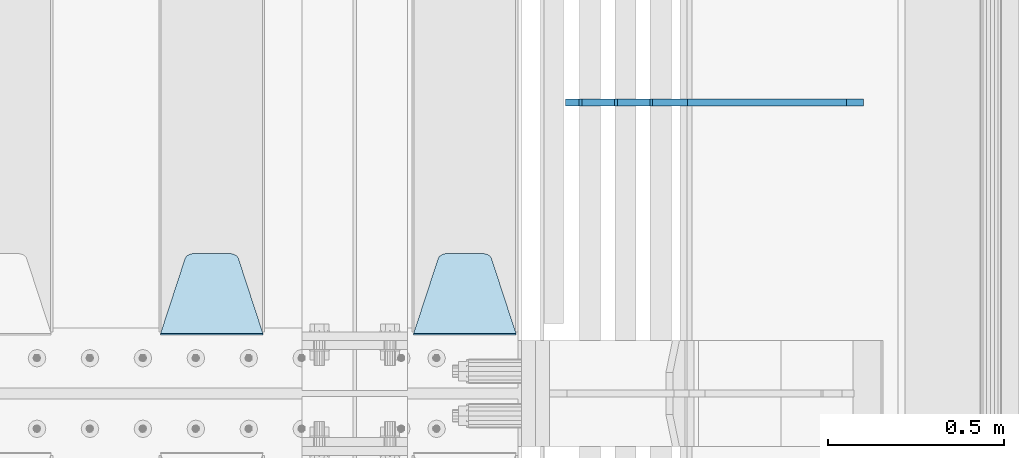
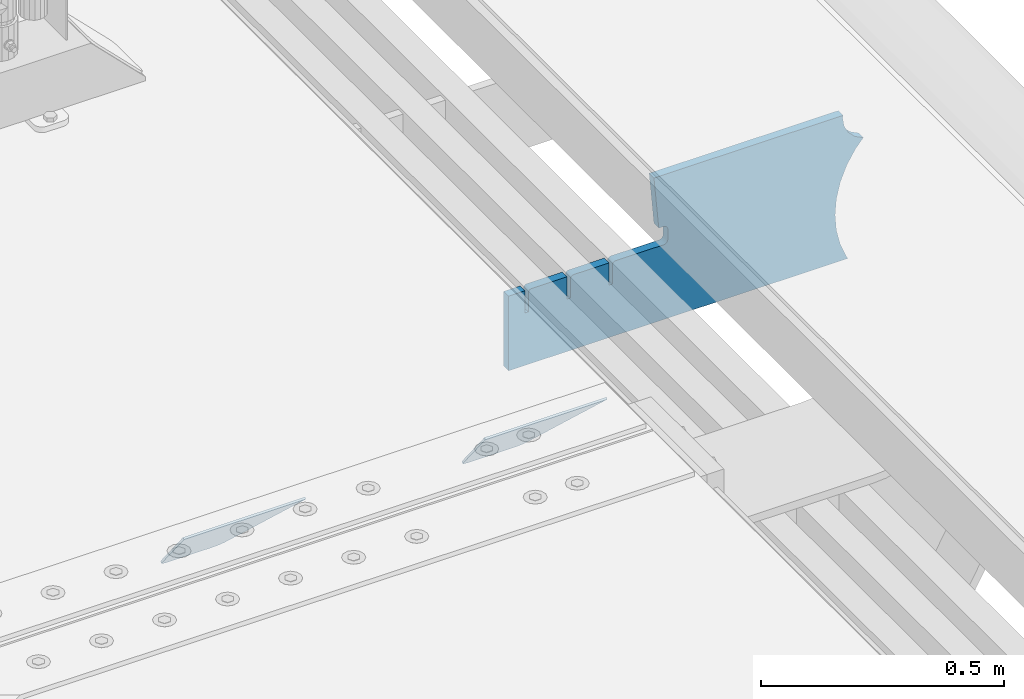
# One storey, part 192 of 219: 3 plates.
"""IFC2X3 building model written with IfcOpenShell, lengths in millimetres."""

from ifc_helpers import new_model, si_unit, frame, origin_with_axes, place, context, subcontext, project, spatial, faceted_brep, material, type_object, element, save


model = new_model("IFC2X3")

# Units and contexts
model_context = context("Model", 3, precision=1e-05, world=origin_with_axes())
body_context = subcontext(model_context, "Body", "Model", "MODEL_VIEW")
ifc_project = project(units=[si_unit("LENGTHUNIT", "METRE", prefix="MILLI"), si_unit("AREAUNIT", "SQUARE_METRE"), si_unit("VOLUMEUNIT", "CUBIC_METRE"), si_unit("MASSUNIT", "GRAM", prefix="KILO"), si_unit("TIMEUNIT", "SECOND"), si_unit("PLANEANGLEUNIT", "RADIAN"), si_unit("SOLIDANGLEUNIT", "STERADIAN"), si_unit("THERMODYNAMICTEMPERATUREUNIT", "DEGREE_CELSIUS"), si_unit("LUMINOUSINTENSITYUNIT", "LUMEN")], contexts=[model_context])

# Site, building, storey
site_placement = place(None, origin_with_axes())
site = spatial("IfcSite", under=ifc_project, at=site_placement, CompositionType="ELEMENT")
building_placement = place(site_placement, origin_with_axes())
building = spatial("IfcBuilding", under=site, at=building_placement, Name="Standard", CompositionType="ELEMENT")
storey_placement = place(building_placement, origin_with_axes())
storey = spatial("IfcBuildingStorey", under=building, at=storey_placement, Name="Undefined", CompositionType="ELEMENT", Elevation=0.0)

# Plates
ifc_material = material(Name="STEEL/S355N")
plate_type_1 = type_object("IfcPlateType", PredefinedType="NOTDEFINED")
plate_1_placement = place(storey_placement, frame((14012.0, 30168.232233047, -1.76776695296758), z_axis=(0.0, 0.707106781186547, -0.707106781186548), x_axis=(-1.0, 0.0, 0.0)))
element("IfcPlate", 1, at=plate_1_placement, inside=storey, type_object=plate_type_1, material=ifc_material, context=body_context, shape_type="Brep", body=[
    faceted_brep([(0.0, -2.5, 0.0), (69.345504679477, -2.5, 300.171731424834), (69.345504679477, 2.49999999999636, 300.171731424831), (0.0, 2.5, 0.0), (70.9274061199576, -2.50000000000364, 304.8974424154), (70.9274061199576, 2.49999999999636, 304.8974424154), (73.3818627772307, -2.50000000000364, 309.234538108532), (73.3818627772307, 2.49999999999636, 309.234538108532), (76.6187032999569, -2.50000000000364, 313.023683126106), (76.6187032999569, 2.49999999999636, 313.023683126106), (80.5190132704993, -2.50000000000364, 316.125672595372), (80.5190132704993, 2.49999999999636, 316.125672595372), (84.9395038596831, -2.50000000000364, 318.426546230476), (84.9395038596831, 2.5, 318.426546230479), (89.7177759439237, -2.50000000000364, 319.841774983277), (89.7177759439237, 2.5, 319.841774983281), (94.6782862926502, -2.50000000000364, 320.319366455078), (94.6782862926502, 2.49999999999636, 320.319366455078), (195.32171370735, -2.50000000000364, 320.319366455078), (195.32171370735, 2.49999999999636, 320.319366455078), (200.282224056076, -2.50000000000364, 319.841774983277), (200.282224056076, 2.5, 319.841774983281), (205.060496140317, -2.50000000000364, 318.426546230476), (205.060496140317, 2.49999999999636, 318.426546230476), (209.480986729501, -2.50000000000364, 316.125672595372), (209.480986729501, 2.49999999999636, 316.125672595372), (213.381296700043, -2.50000000000364, 313.023683126106), (213.381296700043, 2.49999999999272, 313.023683126106), (216.618137222769, -2.50000000000364, 309.234538108529), (216.618137222769, 2.49999999999636, 309.234538108525), (219.072593880042, -2.50000000000364, 304.8974424154), (219.072593880042, 2.49999999999636, 304.8974424154), (220.654495320523, -2.5, 300.171731424834), (220.654495320523, 2.49999999999636, 300.171731424831), (290.0, -2.50000000000364, 3.63797880709171e-12), (290.0, 2.49999999999636, 0.0)], [[[0, 1, 2, 3]], [[1, 4, 5, 2]], [[4, 6, 7, 5]], [[6, 8, 9, 7]], [[8, 10, 11, 9]], [[10, 12, 13, 11]], [[12, 14, 15, 13]], [[14, 16, 17, 15]], [[16, 18, 19, 17]], [[18, 20, 21, 19]], [[20, 22, 23, 21]], [[22, 24, 25, 23]], [[24, 26, 27, 25]], [[26, 28, 29, 27]], [[28, 30, 31, 29]], [[30, 32, 33, 31]], [[32, 34, 35, 33]], [[34, 0, 3, 35]], [[5, 7, 9, 11, 13, 15, 17, 19, 21, 23, 25, 27, 29, 31, 33, 35, 3, 2]], [[34, 32, 30, 28, 26, 24, 22, 20, 18, 16, 14, 12, 10, 8, 6, 4, 1, 0]]]),
])
plate_2_placement = place(storey_placement, frame((13295.0, 30168.232233047, -1.76776695296758), z_axis=(0.0, 0.707106781186547, -0.707106781186548), x_axis=(-1.0, 0.0, 0.0)))
element("IfcPlate", 2, at=plate_2_placement, inside=storey, type_object=plate_type_1, material=ifc_material, context=body_context, shape_type="Brep", body=[
    faceted_brep([(0.0, -2.5, 0.0), (69.345504679477, -2.5, 300.171731424834), (69.345504679477, 2.49999999999636, 300.171731424831), (0.0, 2.5, 0.0), (70.9274061199576, -2.50000000000364, 304.8974424154), (70.9274061199576, 2.49999999999636, 304.8974424154), (73.3818627772307, -2.50000000000364, 309.234538108532), (73.3818627772307, 2.49999999999636, 309.234538108532), (76.6187032999569, -2.50000000000364, 313.023683126106), (76.6187032999569, 2.49999999999636, 313.023683126106), (80.5190132704993, -2.50000000000364, 316.125672595372), (80.5190132704993, 2.49999999999636, 316.125672595372), (84.9395038596831, -2.50000000000364, 318.426546230476), (84.9395038596831, 2.5, 318.426546230479), (89.7177759439237, -2.50000000000364, 319.841774983277), (89.7177759439237, 2.5, 319.841774983281), (94.6782862926502, -2.50000000000364, 320.319366455078), (94.6782862926502, 2.49999999999636, 320.319366455078), (195.32171370735, -2.50000000000364, 320.319366455078), (195.32171370735, 2.49999999999636, 320.319366455078), (200.282224056076, -2.50000000000364, 319.841774983277), (200.282224056076, 2.5, 319.841774983281), (205.060496140317, -2.50000000000364, 318.426546230476), (205.060496140317, 2.49999999999636, 318.426546230476), (209.480986729501, -2.50000000000364, 316.125672595372), (209.480986729501, 2.49999999999636, 316.125672595372), (213.381296700043, -2.50000000000364, 313.023683126106), (213.381296700043, 2.49999999999272, 313.023683126106), (216.618137222769, -2.50000000000364, 309.234538108529), (216.618137222769, 2.49999999999636, 309.234538108525), (219.072593880042, -2.50000000000364, 304.8974424154), (219.072593880042, 2.49999999999636, 304.8974424154), (220.654495320523, -2.5, 300.171731424834), (220.654495320523, 2.49999999999636, 300.171731424831), (290.0, -2.50000000000364, 3.63797880709171e-12), (290.0, 2.49999999999636, 0.0)], [[[0, 1, 2, 3]], [[1, 4, 5, 2]], [[4, 6, 7, 5]], [[6, 8, 9, 7]], [[8, 10, 11, 9]], [[10, 12, 13, 11]], [[12, 14, 15, 13]], [[14, 16, 17, 15]], [[16, 18, 19, 17]], [[18, 20, 21, 19]], [[20, 22, 23, 21]], [[22, 24, 25, 23]], [[24, 26, 27, 25]], [[26, 28, 29, 27]], [[28, 30, 31, 29]], [[30, 32, 33, 31]], [[32, 34, 35, 33]], [[34, 0, 3, 35]], [[5, 7, 9, 11, 13, 15, 17, 19, 21, 23, 25, 27, 29, 31, 33, 35, 3, 2]], [[34, 32, 30, 28, 26, 24, 22, 20, 18, 16, 14, 12, 10, 8, 6, 4, 1, 0]]]),
])
plate_type_2 = type_object("IfcPlateType", PredefinedType="NOTDEFINED")
plate_3_placement = place(storey_placement, frame((14992.9182339676, 30824.9992828369, -374.002067436516), z_axis=(0.0, 0.0, 1.0), x_axis=(-1.0, 0.0, 0.0)))
element("IfcPlate", 3, at=plate_3_placement, inside=storey, type_object=plate_type_2, material=ifc_material, context=body_context, shape_type="Brep", body=[
    faceted_brep([(801.919404066546, -10.0, 188.0), (801.919404066546, 10.0, 188.0), (801.919404066546, 10.0, 132.002067436952), (801.919404066546, -9.99999999999636, 132.002067436952), (793.919404066546, 10.0, 132.002067436952), (793.919404066546, -9.99999999999636, 132.002067436952), (793.919404066546, 10.0, 180.002067436952), (793.919404066546, -10.0, 180.002067436952), (793.527856196908, 10.0, 182.474203391951), (793.527856196908, -10.0, 182.474203391951), (792.391540021546, 10.0, 184.704349455291), (792.391540021546, -10.0, 184.704349455291), (790.621686084885, 10.0, 186.474203391951), (790.621686084885, -10.0, 186.474203391951), (788.391540021546, 10.0, 187.610519567313), (788.391540021546, -10.0, 187.610519567313), (785.919404066546, -10.0, 188.002067436952), (785.919404066546, 10.0, 188.0), (841.0, -10.0, 188.0), (841.0, -10.0, 0.0), (841.0, 10.0, 0.0), (841.0, 10.0, 188.0), (33.3619566736033, -10.0, 0.0), (33.3619566736033, 10.0, 0.0), (36.2350612208174, -10.0, 4.68848050267013), (36.2350612208174, 10.0, 4.68848050267013), (51.487759215941, -10.0, 41.5117508652784), (51.487759215941, 10.0, 41.5117508652784), (60.792242588137, -10.0, 80.2677133162964), (60.792242588137, 10.0, 80.2677133162964), (63.9194040769726, -10.0, 120.002067436515), (63.9194040769726, 10.0, 120.002067436515), (60.792242588137, -10.0, 159.736421556734), (60.792242588137, 10.0, 159.736421556734), (51.487759215941, -10.0, 198.492384007752), (51.487759215941, 10.0, 198.492384007752), (36.2350612208174, -10.0, 235.31565437036), (36.2350612208174, 10.0, 235.31565437036), (15.4097206482093, -10.0, 269.299521518803), (15.4097206482093, 10.0, 269.299521518803), (-3.35474438098936, -10.0, 291.269887256574), (-3.35474438098936, 10.0, 291.269887256574), (-2.36881039375294, -10.0, 291.426043859339), (-2.36881039375294, 10.0, 291.426043859339), (17.1449676604734, -10.0, 301.368810393754), (17.1449676604734, 10.0, 301.368810393754), (32.6311896062471, -10.0, 316.855032339527), (32.6311896062471, 10.0, 316.855032339527), (42.5739561406608, -10.0, 336.368810393754), (42.5739561406608, 10.0, 336.368810393754), (46.0, -10.0, 358.0), (46.0, 10.0, 358.0), (45.0495205499192, -10.0, 364.001091067617), (45.0495205499192, 10.0, 364.001091067617), (495.040008544922, -10.0, 364.010009765625), (495.040008544922, 10.0, 364.010009765625), (483.600036621094, -10.0, 233.759994506836), (483.600036621094, 10.0, 233.759994506836), (472.0, -10.0, 233.759994506836), (472.0, 10.0, 233.759994506836), (468.909830056251, -10.0, 233.270559669787), (468.909830056251, 10.0, 233.270559669787), (466.122147477075, -10.0, 231.850164450585), (466.122147477075, 10.0, 231.850164450585), (463.909830056251, -10.0, 229.637847029761), (463.909830056251, 10.0, 229.637847029761), (462.489434837049, -10.0, 226.850164450585), (462.489434837049, 10.0, 226.850164450585), (462.0, -10.0, 223.759994506836), (462.0, 10.0, 223.759994506836), (462.0, -10.0, 198.0), (462.0, 10.0, 198.0), (462.489434837049, -10.0, 194.909830056251), (462.489434837049, 10.0, 194.909830056251), (463.909830056251, -10.0, 192.122147477075), (463.909830056251, 10.0, 192.122147477075), (466.122147477075, -10.0, 189.909830056251), (466.122147477075, 10.0, 189.909830056251), (468.909830056251, -10.0, 188.489434837048), (468.909830056251, 10.0, 188.489434837048), (472.0, -10.0, 188.0), (472.0, 10.0, 188.0), (585.919404066546, -10.0, 188.002067436952), (585.919404066546, 10.0, 188.0), (588.391540021546, -10.0, 187.610519567313), (588.391540021546, 10.0, 187.610519567313), (590.621686084885, -10.0, 186.474203391951), (590.621686084885, 10.0, 186.474203391951), (592.391540021546, -10.0, 184.704349455291), (592.391540021546, 10.0, 184.704349455291), (593.527856196908, -10.0, 182.474203391951), (593.527856196908, 10.0, 182.474203391951), (593.919404066546, -10.0, 180.002067436952), (593.919404066546, 10.0, 180.002067436952), (593.919404066546, -10.0, 132.002067436952), (593.919404066546, 10.0, 132.002067436952), (601.919404066546, -10.0, 132.002067436952), (601.919404066546, 10.0, 132.002067436952), (601.919404066546, -10.0, 188.0), (601.919404066546, 10.0, 188.0), (685.919404066546, -10.0, 188.002067436952), (685.919404066546, 10.0, 188.0), (688.391540021546, -10.0, 187.610519567313), (688.391540021546, 10.0, 187.610519567313), (690.621686084885, -10.0, 186.474203391951), (690.621686084885, 10.0, 186.474203391951), (692.391540021546, -10.0, 184.704349455291), (692.391540021546, 10.0, 184.704349455291), (693.527856196908, -10.0, 182.474203391951), (693.527856196908, 10.0, 182.474203391951), (693.919404066546, -10.0, 180.002067436952), (693.919404066546, 10.0, 180.002067436952), (693.919404066546, -10.0, 132.002067436952), (693.919404066546, 10.0, 132.002067436952), (701.919404066546, -10.0, 132.002067436952), (701.919404066546, 10.0, 132.002067436952), (701.919404066546, -10.0, 188.0), (701.919404066546, 10.0, 188.0)], [[[0, 1, 2, 3]], [[3, 2, 4, 5]], [[5, 4, 6, 7]], [[7, 6, 8, 9]], [[9, 8, 10, 11]], [[11, 10, 12, 13]], [[13, 12, 14, 15]], [[16, 15, 14, 17]], [[18, 19, 20, 21]], [[20, 19, 22, 23]], [[22, 24, 25, 23]], [[26, 27, 25, 24]], [[28, 29, 27, 26]], [[30, 31, 29, 28]], [[32, 33, 31, 30]], [[34, 35, 33, 32]], [[36, 37, 35, 34]], [[38, 39, 37, 36]], [[39, 38, 40, 41]], [[40, 42, 43, 41]], [[44, 45, 43, 42]], [[46, 47, 45, 44]], [[48, 49, 47, 46]], [[50, 51, 49, 48]], [[52, 53, 51, 50]], [[54, 55, 53, 52]], [[54, 56, 57, 55]], [[56, 58, 59, 57]], [[58, 60, 61, 59]], [[60, 62, 63, 61]], [[62, 64, 65, 63]], [[64, 66, 67, 65]], [[66, 68, 69, 67]], [[68, 70, 71, 69]], [[70, 72, 73, 71]], [[72, 74, 75, 73]], [[74, 76, 77, 75]], [[76, 78, 79, 77]], [[78, 80, 81, 79]], [[81, 80, 82, 83]], [[82, 84, 85, 83]], [[86, 87, 85, 84]], [[88, 89, 87, 86]], [[90, 91, 89, 88]], [[92, 93, 91, 90]], [[94, 95, 93, 92]], [[96, 97, 95, 94]], [[98, 99, 97, 96]], [[99, 98, 100, 101]], [[100, 102, 103, 101]], [[104, 105, 103, 102]], [[106, 107, 105, 104]], [[108, 109, 107, 106]], [[110, 111, 109, 108]], [[112, 113, 111, 110]], [[114, 115, 113, 112]], [[116, 117, 115, 114]], [[117, 116, 16, 17]], [[12, 10, 8, 6, 4, 2, 1, 21, 20, 23, 25, 27, 29, 31, 33, 35, 37, 39, 41, 43, 45, 47, 49, 51, 53, 55, 57, 59, 61, 63, 65, 67, 69, 71, 73, 75, 77, 79, 81, 83, 85, 87, 89, 91, 93, 95, 97, 99, 101, 103, 105, 107, 109, 111, 113, 115, 117, 17, 14]], [[18, 21, 1, 0]], [[116, 114, 112, 110, 108, 106, 104, 102, 100, 98, 96, 94, 92, 90, 88, 86, 84, 82, 80, 78, 76, 74, 72, 70, 68, 66, 64, 62, 60, 58, 56, 54, 52, 50, 48, 46, 44, 42, 40, 38, 36, 34, 32, 30, 28, 26, 24, 22, 19, 18, 0, 3, 5, 7, 9, 11, 13, 15, 16]]]),
])

save(model, "model.ifc")
